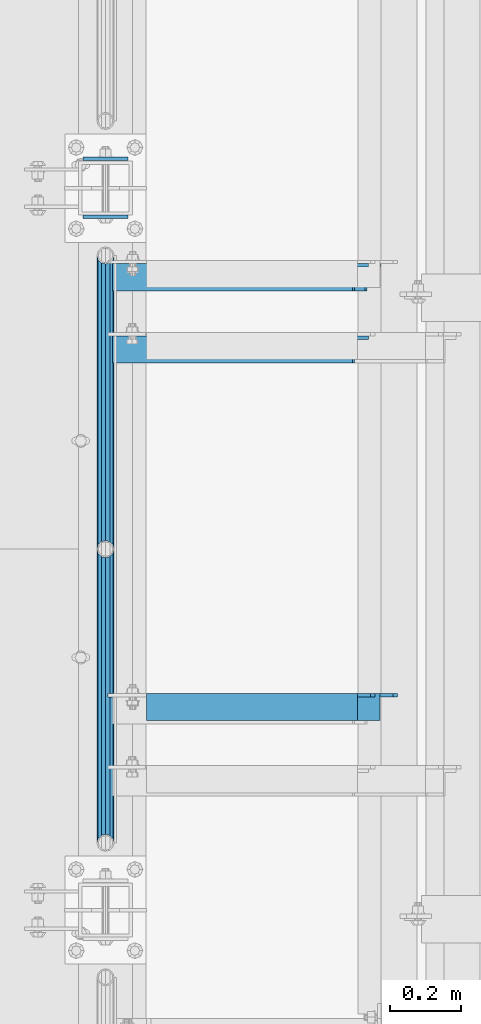
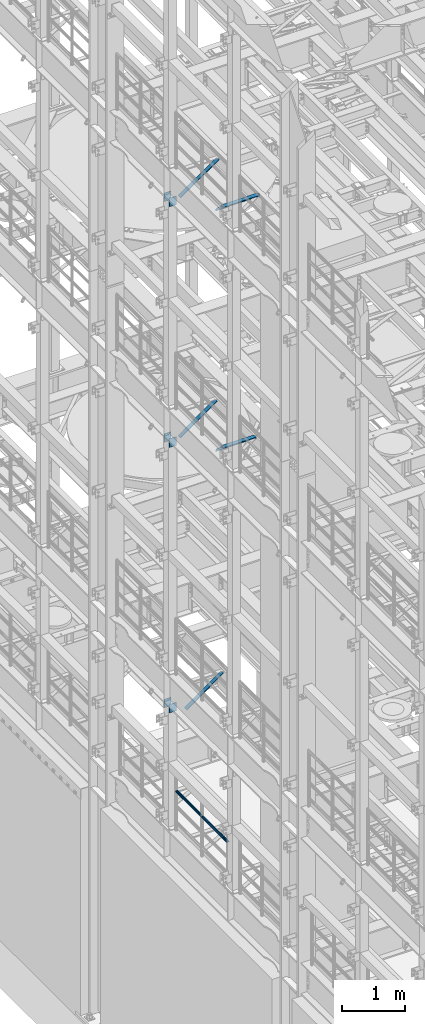
# One storey, part 1254 of 1876: 10 beams, 3 members, 9 elements without a shape of their own.
"""IFC2X3 building model written with IfcOpenShell, lengths in millimetres."""

from ifc_helpers import new_model, si_unit, frame, origin_with_axes, place, context, subcontext, project, spatial, faceted_brep, material, type_object, element, aggregate, save


model = new_model("IFC2X3")

# Units and contexts
model_context = context("Model", 3, precision=1e-05, world=origin_with_axes())
body_context = subcontext(model_context, "Body", "Model", "MODEL_VIEW")
ifc_project = project(units=[si_unit("LENGTHUNIT", "METRE", prefix="MILLI"), si_unit("AREAUNIT", "SQUARE_METRE"), si_unit("VOLUMEUNIT", "CUBIC_METRE"), si_unit("MASSUNIT", "GRAM", prefix="KILO"), si_unit("TIMEUNIT", "SECOND"), si_unit("PLANEANGLEUNIT", "RADIAN"), si_unit("SOLIDANGLEUNIT", "STERADIAN"), si_unit("THERMODYNAMICTEMPERATUREUNIT", "DEGREE_CELSIUS"), si_unit("LUMINOUSINTENSITYUNIT", "LUMEN")], contexts=[model_context])

# Site, building, storey
site_placement = place(None, origin_with_axes())
site = spatial("IfcSite", under=ifc_project, at=site_placement, CompositionType="ELEMENT")
building_placement = place(site_placement, origin_with_axes())
building = spatial("IfcBuilding", under=site, at=building_placement, Name="Undefined", CompositionType="ELEMENT")
storey_placement = place(building_placement, origin_with_axes())
storey = spatial("IfcBuildingStorey", under=building, at=storey_placement, Name="Undefined", CompositionType="ELEMENT", Elevation=0.0)

# Assembly, beams
assembly_1_placement = place(storey_placement, origin_with_axes())
assembly_1 = element("IfcElementAssembly", 1, at=assembly_1_placement, inside=storey, Name="RAIL", AssemblyPlace="NOTDEFINED", PredefinedType="RIGID_FRAME")
ifc_material_1 = material()
beam_type_1 = type_object("IfcBeamType", Name="PIPE1-1/2SCH40", PredefinedType="NOTDEFINED")
beam_1_placement = place(assembly_1_placement, frame((-1.81898940354586e-12, 3745.23, 5902.325), z_axis=(0.0, 0.0, -1.0), x_axis=(0.0, 1.0, 0.0)))
beam_1 = element("IfcBeam", 2, at=beam_1_placement, type_object=beam_type_1, material=ifc_material_1, Name="RAIL", ObjectType="PIPE1-1/2SCH40", context=body_context, shape_type="Brep", body=[
    faceted_brep([(0.0, 24.1299999999992, 0.0), (12.0650000000064, 20.8971929933177, -12.0649999999987), (12.0650000000064, 20.8971929933177, 12.0649999999987), (12.0650000000064, -20.8971929933177, 12.0649999999987), (12.0650000000064, -20.8971929933177, -12.0649999999987), (0.0, -24.1299999999992, 0.0), (20.8971929933249, -12.0650000000005, 20.8971929933177), (20.8971929933249, -12.0650000000005, 15.8661214311796), (15.2545715621445, -17.7076214311801, 10.2235000000001), (12.5151929933249, -20.4470000000001, 0.0), (15.2545715621445, -17.7076214311801, -10.2235000000001), (20.8971929933249, -12.0650000000005, -15.8661214311796), (20.8971929933249, -12.0650000000005, -20.8971929933177), (24.1300000000063, 0.0, -20.4470000000001), (24.1300000000063, 0.0, -24.130000000001), (21.3906214311868, -10.2235000000001, -17.7076214311819), (21.3906214311868, 10.2235000000001, -17.7076214311819), (20.8971929933249, 12.0650000000005, -15.8661214311796), (20.8971929933249, 12.0650000000005, -20.8971929933177), (15.2545715621445, 17.7076214311801, -10.2235000000001), (12.5151929933249, 20.4470000000001, 0.0), (15.2545715621445, 17.7076214311801, 10.2235000000001), (20.8971929933249, 12.0650000000005, 15.8661214311796), (20.8971929933249, 12.0650000000005, 20.8971929933177), (21.3906214311868, 10.2235000000001, 17.7076214311819), (24.1300000000064, 0.0, 20.4470000000001), (24.1300000000064, 0.0, 24.130000000001), (21.3906214311868, -10.2235000000001, 17.7076214311819), (826.77, 24.1300000000001, 0.0), (814.705, 20.8971929933186, -12.0649999999987), (805.872807006681, 12.0649999999996, -20.8971929933177), (826.77, -24.1300000000001, 0.0), (814.705, -20.8971929933186, -12.0649999999987), (814.705, -20.8971929933186, 12.0649999999987), (805.872807006681, -12.0649999999996, 20.8971929933177), (805.872807006681, -12.0649999999996, -20.8971929933177), (802.640000000001, 0.0, -24.130000000001), (805.379378568819, 10.2235000000001, -17.7076214311819), (802.640000000001, 0.0, -20.4470000000001), (805.872807006683, 12.0649999999996, -15.8661214311796), (805.872807006683, -12.0649999999996, -15.8661214311796), (805.379378568819, -10.2235000000001, -17.7076214311819), (811.515428437862, -17.7076214311801, -10.2235000000001), (814.254807006682, -20.4470000000001, 0.0), (811.515428437862, -17.7076214311801, 10.2235000000001), (805.872807006683, -12.0649999999996, 15.8661214311796), (805.379378568819, -10.2235000000001, 17.7076214311819), (802.640000000001, 0.0, 20.4470000000001), (802.640000000001, 0.0, 24.130000000001), (805.872807006681, 12.0649999999996, 20.8971929933177), (814.705, 20.8971929933186, 12.0649999999987), (805.872807006683, 12.0649999999996, 15.8661214311796), (811.515428437862, 17.7076214311801, 10.2235000000001), (814.254807006682, 20.4470000000001, 0.0), (811.515428437862, 17.7076214311801, -10.2235000000001), (805.379378568819, 10.2235000000001, 17.7076214311819)], [[[0, 1, 2]], [[3, 4, 5]], [[6, 7, 8, 9, 10, 11, 12, 4, 3]], [[13, 14, 12, 11, 15]], [[16, 17, 18, 14, 13]], [[2, 1, 18, 17, 19, 20, 21, 22, 23]], [[23, 22, 24, 25, 26]], [[26, 25, 27, 7, 6]], [[1, 0, 28, 29]], [[18, 1, 29, 30]], [[31, 32, 33]], [[6, 3, 33, 34]], [[3, 5, 31, 33]], [[5, 4, 32, 31]], [[4, 12, 35, 32]], [[12, 14, 36, 35]], [[14, 18, 30, 36]], [[37, 38, 36, 30, 39]], [[40, 35, 36, 38, 41]], [[33, 32, 35, 40, 42, 43, 44, 45, 34]], [[34, 45, 46, 47, 48]], [[26, 6, 34, 48]], [[2, 23, 49, 50]], [[23, 26, 48, 49]], [[0, 2, 50, 28]], [[28, 50, 29]], [[49, 51, 52, 53, 54, 39, 30, 29, 50]], [[48, 47, 55, 51, 49]], [[25, 24, 55, 47]], [[55, 24, 22, 21, 52, 51]], [[21, 20, 53, 52]], [[20, 19, 54, 53]], [[19, 17, 16, 37, 39, 54]], [[16, 13, 38, 37]], [[13, 15, 41, 38]], [[41, 15, 11, 10, 42, 40]], [[10, 9, 43, 42]], [[9, 8, 44, 43]], [[8, 7, 27, 46, 45, 44]], [[27, 25, 47, 46]]]),
])
beam_2_placement = place(assembly_1_placement, frame((-1.81898940354586e-12, 4572.0, 5902.325), z_axis=(0.0, 0.0, -1.0), x_axis=(0.0, 1.0, 0.0)))
beam_2 = element("IfcBeam", 3, at=beam_2_placement, type_object=beam_type_1, material=ifc_material_1, Name="RAIL", ObjectType="PIPE1-1/2SCH40", context=body_context, shape_type="Brep", body=[
    faceted_brep([(0.0, 24.1299999999992, 0.0), (12.0650000000064, 20.8971929933177, -12.0649999999987), (12.0650000000064, 20.8971929933177, 12.0649999999987), (12.0650000000064, -20.8971929933177, 12.0649999999987), (12.0650000000064, -20.8971929933177, -12.0649999999987), (0.0, -24.1299999999992, 0.0), (20.8971929933249, -12.0650000000005, 20.8971929933177), (20.8971929933249, -12.0650000000005, 15.8661214311796), (15.2545715621445, -17.7076214311801, 10.2235000000001), (12.5151929933249, -20.4470000000001, 0.0), (15.2545715621445, -17.7076214311801, -10.2235000000001), (20.8971929933249, -12.0650000000005, -15.8661214311796), (20.8971929933249, -12.0650000000005, -20.8971929933177), (24.1300000000063, 0.0, -20.4470000000001), (24.1300000000063, 0.0, -24.130000000001), (21.3906214311868, -10.2235000000001, -17.7076214311819), (21.3906214311868, 10.2235000000001, -17.7076214311819), (20.8971929933249, 12.0650000000005, -15.8661214311796), (20.8971929933249, 12.0650000000005, -20.8971929933177), (15.2545715621445, 17.7076214311801, -10.2235000000001), (12.5151929933249, 20.4470000000001, 0.0), (15.2545715621445, 17.7076214311801, 10.2235000000001), (20.8971929933249, 12.0650000000005, 15.8661214311796), (20.8971929933249, 12.0650000000005, 20.8971929933177), (21.3906214311868, 10.2235000000001, 17.7076214311819), (24.1300000000064, 0.0, 20.4470000000001), (24.1300000000064, 0.0, 24.130000000001), (21.3906214311868, -10.2235000000001, 17.7076214311819), (826.77, 24.1300000000001, 0.0), (814.705, 20.8971929933186, -12.0649999999987), (805.872807006681, 12.0649999999996, -20.8971929933177), (826.77, -24.1300000000001, 0.0), (814.705, -20.8971929933186, -12.0649999999987), (814.705, -20.8971929933186, 12.0649999999987), (805.872807006681, -12.0649999999996, 20.8971929933177), (805.872807006681, -12.0649999999996, -20.8971929933177), (802.640000000001, 0.0, -24.130000000001), (805.379378568819, 10.2235000000001, -17.7076214311819), (802.640000000001, 0.0, -20.4470000000001), (805.872807006683, 12.0649999999996, -15.8661214311796), (805.872807006683, -12.0649999999996, -15.8661214311796), (805.379378568819, -10.2235000000001, -17.7076214311819), (811.515428437862, -17.7076214311801, -10.2235000000001), (814.254807006682, -20.4470000000001, 0.0), (811.515428437862, -17.7076214311801, 10.2235000000001), (805.872807006683, -12.0649999999996, 15.8661214311796), (805.379378568819, -10.2235000000001, 17.7076214311819), (802.640000000001, 0.0, 20.4470000000001), (802.640000000001, 0.0, 24.130000000001), (805.872807006681, 12.0649999999996, 20.8971929933177), (814.705, 20.8971929933186, 12.0649999999987), (805.872807006683, 12.0649999999996, 15.8661214311796), (811.515428437862, 17.7076214311801, 10.2235000000001), (814.254807006682, 20.4470000000001, 0.0), (811.515428437862, 17.7076214311801, -10.2235000000001), (805.379378568819, 10.2235000000001, 17.7076214311819)], [[[0, 1, 2]], [[3, 4, 5]], [[6, 7, 8, 9, 10, 11, 12, 4, 3]], [[13, 14, 12, 11, 15]], [[16, 17, 18, 14, 13]], [[2, 1, 18, 17, 19, 20, 21, 22, 23]], [[23, 22, 24, 25, 26]], [[26, 25, 27, 7, 6]], [[1, 0, 28, 29]], [[18, 1, 29, 30]], [[31, 32, 33]], [[6, 3, 33, 34]], [[3, 5, 31, 33]], [[5, 4, 32, 31]], [[4, 12, 35, 32]], [[12, 14, 36, 35]], [[14, 18, 30, 36]], [[37, 38, 36, 30, 39]], [[40, 35, 36, 38, 41]], [[33, 32, 35, 40, 42, 43, 44, 45, 34]], [[34, 45, 46, 47, 48]], [[26, 6, 34, 48]], [[2, 23, 49, 50]], [[23, 26, 48, 49]], [[0, 2, 50, 28]], [[28, 50, 29]], [[49, 51, 52, 53, 54, 39, 30, 29, 50]], [[48, 47, 55, 51, 49]], [[25, 24, 55, 47]], [[55, 24, 22, 21, 52, 51]], [[21, 20, 53, 52]], [[20, 19, 54, 53]], [[19, 17, 16, 37, 39, 54]], [[16, 13, 38, 37]], [[13, 15, 41, 38]], [[41, 15, 11, 10, 42, 40]], [[10, 9, 43, 42]], [[9, 8, 44, 43]], [[8, 7, 27, 46, 45, 44]], [[27, 25, 47, 46]]]),
])
aggregate(assembly_1, [beam_1, beam_2])

assembly_2_placement = place(storey_placement, origin_with_axes())
assembly_2 = element("IfcElementAssembly", 4, at=assembly_2_placement, inside=storey, Name="BEAM", AssemblyPlace="NOTDEFINED", PredefinedType="RIGID_FRAME")
ifc_material_2 = material(Name="STEEL/A36")
beam_type_2 = type_object("IfcBeamType", PredefinedType="NOTDEFINED")
beam_3_placement = place(assembly_2_placement, frame((-63.6296757345187, 5670.55, 7448.54714244377), z_axis=(5.59490000219896e-05, 0.0, -0.999999998434855), x_axis=(0.999999998434855, 0.0, 5.59490000219868e-05)))
beam_3 = element("IfcBeam", 5, at=beam_3_placement, type_object=beam_type_2, material=ifc_material_2, Name="PLATE", context=body_context, shape_type="Brep", body=[
    faceted_brep([(0.0, 4.76249999999982, -82.5499999999993), (0.0, 4.76249999999982, 82.5499999999993), (127.0, 4.76249999999982, 82.5499999999993), (127.0, 4.76249999999982, -82.5499999999993), (0.0, -4.76249999999982, 82.5499999999993), (127.0, -4.76249999999982, 82.5499999999993), (0.0, -4.76249999999982, -82.5499999999993), (127.0, -4.76249999999982, -82.5499999999993)], [[[0, 1, 2, 3]], [[1, 4, 5, 2]], [[4, 6, 7, 5]], [[6, 0, 3, 7]], [[5, 7, 3, 2]], [[6, 4, 1, 0]]]),
])
beam_4_placement = place(assembly_2_placement, frame((-63.6296757345187, 5507.0375, 7448.54714244377), z_axis=(5.59490000219896e-05, 0.0, -0.999999998434855), x_axis=(0.999999998434855, 0.0, 5.59490000219868e-05)))
beam_4 = element("IfcBeam", 6, at=beam_4_placement, type_object=beam_type_2, material=ifc_material_2, Name="PLATE", context=body_context, shape_type="Brep", body=[
    faceted_brep([(0.0, 4.76249999999982, -82.5499999999993), (0.0, 4.76249999999982, 82.5499999999993), (127.0, 4.76249999999982, 82.5499999999993), (127.0, 4.76249999999982, -82.5499999999993), (0.0, -4.76249999999982, 82.5499999999993), (127.0, -4.76249999999982, 82.5499999999993), (0.0, -4.76249999999982, -82.5499999999993), (127.0, -4.76249999999982, -82.5499999999993)], [[[0, 1, 2, 3]], [[1, 4, 5, 2]], [[4, 6, 7, 5]], [[6, 0, 3, 7]], [[5, 7, 3, 2]], [[6, 4, 1, 0]]]),
])
aggregate(assembly_2, [beam_3, beam_4])

assembly_3_placement = place(storey_placement, origin_with_axes())
assembly_3 = element("IfcElementAssembly", 7, at=assembly_3_placement, inside=storey, Name="BEAM", AssemblyPlace="NOTDEFINED", PredefinedType="RIGID_FRAME")
beam_5_placement = place(assembly_3_placement, frame((-63.6315195800257, 5670.55, 12604.7488224823), z_axis=(2.95459999824743e-05, 0.0, -0.999999999563517), x_axis=(0.999999999563517, 0.0, 2.95459999828704e-05)))
beam_5 = element("IfcBeam", 8, at=beam_5_placement, type_object=beam_type_2, material=ifc_material_2, Name="PLATE", context=body_context, shape_type="Brep", body=[
    faceted_brep([(0.0, 4.76249999999982, -82.5499999999993), (0.0, 4.76249999999982, 82.5499999999993), (127.0, 4.76249999999982, 82.5499999999993), (127.0, 4.76249999999982, -82.5499999999993), (0.0, -4.76249999999982, 82.5499999999993), (127.0, -4.76249999999982, 82.5499999999993), (0.0, -4.76249999999982, -82.5499999999993), (127.0, -4.76249999999982, -82.5499999999993)], [[[0, 1, 2, 3]], [[1, 4, 5, 2]], [[4, 6, 7, 5]], [[6, 0, 3, 7]], [[5, 7, 3, 2]], [[6, 4, 1, 0]]]),
])
beam_6_placement = place(assembly_3_placement, frame((-63.6315195800257, 5507.0375, 12604.7488224823), z_axis=(2.95459999824743e-05, 0.0, -0.999999999563517), x_axis=(0.999999999563517, 0.0, 2.95459999828704e-05)))
beam_6 = element("IfcBeam", 9, at=beam_6_placement, type_object=beam_type_2, material=ifc_material_2, Name="PLATE", context=body_context, shape_type="Brep", body=[
    faceted_brep([(0.0, 4.76249999999982, -82.5499999999993), (0.0, 4.76249999999982, 82.5499999999993), (127.0, 4.76249999999982, 82.5499999999993), (127.0, 4.76249999999982, -82.5499999999993), (0.0, -4.76249999999982, 82.5499999999993), (127.0, -4.76249999999982, 82.5499999999993), (0.0, -4.76249999999982, -82.5499999999993), (127.0, -4.76249999999982, -82.5499999999993)], [[[0, 1, 2, 3]], [[1, 4, 5, 2]], [[4, 6, 7, 5]], [[6, 0, 3, 7]], [[5, 7, 3, 2]], [[6, 4, 1, 0]]]),
])
aggregate(assembly_3, [beam_5, beam_6])

assembly_4_placement = place(storey_placement, origin_with_axes())
assembly_4 = element("IfcElementAssembly", 10, at=assembly_4_placement, inside=storey, Name="BEAM", AssemblyPlace="NOTDEFINED", PredefinedType="RIGID_FRAME")
beam_7_placement = place(assembly_4_placement, frame((-63.5, 5670.55, 17278.35), z_axis=(0.0, 0.0, -1.0), x_axis=(1.0, 0.0, 0.0)))
beam_7 = element("IfcBeam", 11, at=beam_7_placement, type_object=beam_type_2, material=ifc_material_2, Name="PLATE", context=body_context, shape_type="Brep", body=[
    faceted_brep([(0.0, 4.76249999999982, -82.5499999999993), (0.0, 4.76249999999982, 82.5499999999993), (127.0, 4.76249999999982, 82.5499999999993), (127.0, 4.76249999999982, -82.5499999999993), (0.0, -4.76249999999982, 82.5499999999993), (127.0, -4.76249999999982, 82.5499999999993), (0.0, -4.76249999999982, -82.5499999999993), (127.0, -4.76249999999982, -82.5499999999993)], [[[0, 1, 2, 3]], [[1, 4, 5, 2]], [[4, 6, 7, 5]], [[6, 0, 3, 7]], [[5, 7, 3, 2]], [[6, 4, 1, 0]]]),
])
beam_8_placement = place(assembly_4_placement, frame((-63.5, 5507.0375, 17278.35), z_axis=(0.0, 0.0, -1.0), x_axis=(1.0, 0.0, 0.0)))
beam_8 = element("IfcBeam", 12, at=beam_8_placement, type_object=beam_type_2, material=ifc_material_2, Name="PLATE", context=body_context, shape_type="Brep", body=[
    faceted_brep([(0.0, 4.76249999999982, -82.5499999999993), (0.0, 4.76249999999982, 82.5499999999993), (127.0, 4.76249999999982, 82.5499999999993), (127.0, 4.76249999999982, -82.5499999999993), (0.0, -4.76249999999982, 82.5499999999993), (127.0, -4.76249999999982, 82.5499999999993), (0.0, -4.76249999999982, -82.5499999999993), (127.0, -4.76249999999982, -82.5499999999993)], [[[0, 1, 2, 3]], [[1, 4, 5, 2]], [[4, 6, 7, 5]], [[6, 0, 3, 7]], [[5, 7, 3, 2]], [[6, 4, 1, 0]]]),
])
aggregate(assembly_4, [beam_7, beam_8])

# Assembly, member
assembly_5_placement = place(storey_placement, origin_with_axes())
assembly_5 = element("IfcElementAssembly", 13, at=assembly_5_placement, inside=storey, AssemblyPlace="NOTDEFINED", PredefinedType="RIGID_FRAME")
member_type = type_object("IfcMemberType", Name="L3X3X3/8", PredefinedType="NOTDEFINED")
member_1_placement = place(assembly_5_placement, frame((22.1939709589552, 5133.975, 7601.73169287095), z_axis=(0.0, -1.0, 0.0), x_axis=(0.812817140855119, 0.0, 0.582518922896166)))
member_1 = element("IfcMember", 14, at=member_1_placement, type_object=member_type, material=ifc_material_2, ObjectType="L3X3X3/8", context=body_context, shape_type="Brep", body=[
    faceted_brep([(24.4135476554111, 38.1000000000058, -38.0999999999999), (24.4135476554111, 38.1000000000058, 38.0999999999999), (855.72322987264, 38.1000000000749, 38.0999999999999), (855.72322987264, 38.1000000000749, -38.0999999999999), (24.4135476554093, 28.5750000000053, 38.0999999999999), (855.723229872639, 28.5750000000744, 38.0999999999999), (24.4135476554093, 28.5750000000053, -28.5749999999998), (855.723229872639, 28.5750000000744, -28.5749999999998), (24.4135476553975, -38.1000000000031, -28.5749999999998), (855.723229872628, -38.0999999999331, -28.5749999999998), (24.4135476553975, -38.1000000000031, -38.0999999999999), (855.723229872628, -38.0999999999331, -38.0999999999999)], [[[0, 1, 2, 3]], [[1, 4, 5, 2]], [[4, 6, 7, 5]], [[6, 8, 9, 7]], [[8, 10, 11, 9]], [[10, 0, 3, 11]], [[5, 7, 9, 11, 3, 2]], [[10, 8, 6, 4, 1, 0]]]),
])
aggregate(assembly_5, [member_1])

assembly_6_placement = place(storey_placement, origin_with_axes())
assembly_6 = element("IfcElementAssembly", 15, at=assembly_6_placement, inside=storey, Name="BRACE", AssemblyPlace="NOTDEFINED", PredefinedType="RIGID_FRAME")
member_2_placement = place(assembly_6_placement, frame((22.1939716660531, 5337.175, 12757.9316674292), z_axis=(0.0, -1.0, 0.0), x_axis=(0.812817140855119, 0.0, 0.582518922896166)))
member_2 = element("IfcMember", 16, at=member_2_placement, type_object=member_type, material=ifc_material_2, Name="BRACE", ObjectType="L3X3X3/8", context=body_context, shape_type="Brep", body=[
    faceted_brep([(855.723229872639, 28.5750000000744, 38.0999999999999), (855.723229872639, 28.5750000000744, -28.5749999999998), (855.723229872628, -38.0999999999331, -28.5749999999998), (855.723229872628, -38.0999999999331, -38.0999999999999), (855.72322987264, 38.1000000000749, -38.0999999999999), (855.72322987264, 38.1000000000749, 38.0999999999999), (24.4135476554093, 28.5750000000053, 38.0999999999999), (24.4135476554093, 28.5750000000053, -28.5749999999998), (24.4135476553975, -38.1000000000031, -28.5749999999998), (24.4135476553975, -38.1000000000031, -38.0999999999999), (24.4135476554111, 38.1000000000058, -38.0999999999999), (24.4135476554111, 38.1000000000058, 38.0999999999999)], [[[0, 1, 2, 3, 4, 5]], [[6, 7, 1, 0]], [[7, 8, 2, 1]], [[8, 9, 3, 2]], [[9, 10, 4, 3]], [[10, 11, 5, 4]], [[11, 6, 0, 5]], [[9, 8, 7, 6, 11, 10]]]),
])
aggregate(assembly_6, [member_2])

assembly_7_placement = place(storey_placement, origin_with_axes())
assembly_7 = element("IfcElementAssembly", 17, at=assembly_7_placement, inside=storey, AssemblyPlace="NOTDEFINED", PredefinedType="RIGID_FRAME")
member_3_placement = place(assembly_7_placement, frame((21.6869001657126, 5337.175, 17424.2669187563), z_axis=(0.0, -1.0, 0.0), x_axis=(0.822192192147785, 0.0, 0.569209978102299)))
member_3 = element("IfcMember", 18, at=member_3_placement, type_object=member_type, material=ifc_material_2, ObjectType="L3X3X3/8", context=body_context, shape_type="Brep", body=[
    faceted_brep([(24.1351720308776, 38.0999999999403, -38.1000000000004), (24.1351720308776, 38.0999999999403, 38.0999999999999), (887.866654075793, 38.0999999989017, 38.0999999999999), (887.866654075793, 38.0999999989017, -38.1000000000004), (24.135172030894, 28.5749999999462, 38.0999999999999), (887.866654075808, 28.5749999989075, 38.0999999999999), (24.135172030894, 28.5749999999462, -28.5749999999998), (887.866654075808, 28.5749999989075, -28.5749999999998), (24.1351720310122, -38.0999999999985, -28.5749999999998), (887.86665407593, -38.1000000010354, -28.5749999999998), (24.1351720310122, -38.0999999999985, -38.1000000000004), (887.86665407593, -38.1000000010354, -38.1000000000004)], [[[0, 1, 2, 3]], [[1, 4, 5, 2]], [[4, 6, 7, 5]], [[6, 8, 9, 7]], [[8, 10, 11, 9]], [[10, 0, 3, 11]], [[5, 7, 9, 11, 3, 2]], [[10, 8, 6, 4, 1, 0]]]),
])
aggregate(assembly_7, [member_3])

# Assembly, beam
assembly_8_placement = place(storey_placement, origin_with_axes())
assembly_8 = element("IfcElementAssembly", 19, at=assembly_8_placement, inside=storey, Name="ANGLE", AssemblyPlace="NOTDEFINED", PredefinedType="RIGID_FRAME")
beam_type_3 = type_object("IfcBeamType", Name="L3X3X3/8", PredefinedType="NOTDEFINED")
beam_9_placement = place(assembly_8_placement, frame((-1.44313229599957e-09, 4127.5, 17945.1), z_axis=(0.0, -1.0, 0.0), x_axis=(1.0, 0.0, 0.0)))
beam_9 = element("IfcBeam", 20, at=beam_9_placement, type_object=beam_type_3, material=ifc_material_2, Name="ANGLE", ObjectType="L3X3X3/8", context=body_context, shape_type="Brep", body=[
    faceted_brep([(773.112500001443, 28.5750000000007, -28.5749999999998), (773.112500001443, 28.5750000000007, 38.0999999999999), (115.886999817316, 28.5750000000007, 38.0999999999999), (115.88699895052, 28.5750000000007, -28.5749999999998), (773.112500001443, 38.0999999999985, 38.0999999999999), (115.886999817316, 38.0999999999985, 38.0999999999999), (115.886998950515, 12.699999237062, -28.5749999999998), (115.88699882669, 12.699999237062, -38.0999999999999), (38.8937432114558, 12.699999237062, -38.0999999999999), (38.8937433352807, 12.699999237062, -28.5749999999998), (115.886998826692, 38.0999999999985, -38.0999999999999), (773.112500001443, 38.0999999999985, -38.1000000000004), (773.112500001443, 28.5750000000007, -38.1000000000004), (809.625001718057, 28.5750000000007, -28.5749999999998), (809.625001718057, 28.5750000000007, -38.1000000000004), (822.325001527322, 15.8750001907356, -28.5749999999998), (822.325001527322, 15.8750001907356, -38.1000000000004), (822.325001527322, -38.1000030517571, -28.5749999999998), (822.325001527322, -38.0999999999985, -38.1000000000004), (7.1437499954859, -38.0999999999985, -28.5749999999998), (7.1437499954859, -38.0999999999985, -38.0999999999999), (7.14374321145577, -19.050000762938, -38.0999999999999), (7.14374333528067, -19.050000762938, -28.5749999999998)], [[[0, 1, 2, 3]], [[1, 4, 5, 2]], [[6, 7, 8, 9]], [[2, 5, 10, 7, 6, 3]], [[4, 11, 10, 5]], [[1, 0, 12, 11, 4]], [[13, 14, 12, 0]], [[15, 16, 14, 13]], [[17, 18, 16, 15]], [[18, 17, 19, 20]], [[8, 7, 10, 11, 12, 14, 16, 18, 20, 21]], [[9, 8, 21, 22]], [[17, 15, 13, 0, 3, 6, 9, 22, 19]], [[21, 20, 19, 22]]]),
])
aggregate(assembly_8, [beam_9])

assembly_9_placement = place(storey_placement, origin_with_axes())
assembly_9 = element("IfcElementAssembly", 21, at=assembly_9_placement, inside=storey, Name="ANGLE", AssemblyPlace="NOTDEFINED", PredefinedType="RIGID_FRAME")
beam_10_placement = place(assembly_9_placement, frame((-8.61482369428009e-09, 4127.5, 13271.5), z_axis=(0.0, -1.0, 0.0), x_axis=(1.0, 0.0, 0.0)))
beam_10 = element("IfcBeam", 22, at=beam_10_placement, type_object=beam_type_3, material=ifc_material_2, Name="ANGLE", ObjectType="L3X3X3/8", context=body_context, shape_type="Brep", body=[
    faceted_brep([(115.886999817316, 28.5750000000007, 38.0999999999999), (115.886999817316, 38.0999999999985, 38.0999999999999), (115.886998826692, 38.0999999999985, -38.0999999999999), (115.88699882669, 12.699999237062, -38.0999999999999), (115.886998950515, 12.699999237062, -28.5749999999998), (115.88699895052, 28.5750000000007, -28.5749999999998), (38.8937432114558, 12.699999237062, -38.0999999999999), (38.8937433352807, 12.699999237062, -28.5749999999998), (7.14374321145577, -19.050000762938, -38.0999999999999), (7.14374333528067, -19.050000762938, -28.5749999999998), (7.1437499954859, -38.0999999999985, -38.0999999999999), (7.1437499954859, -38.0999999999985, -28.5749999999998), (758.82500204062, 14.2880005577626, -28.5749999999998), (746.125002396449, 26.9880005321429, -28.5749999999998), (709.613000600291, 26.9880010068428, -28.5749999999998), (709.61300062358, 28.5749999999998, -28.5749999999998), (758.824999999999, -38.1000000000004, -28.5749999999998), (758.825001875526, 1.58799979482319, -28.5749999999998), (709.613002423808, 28.5749999999998, 38.1000000000004), (709.613002423808, 38.1000000000004, 38.1000000000004), (709.613000366395, 38.1000000000004, -38.1000000000004), (709.613000343115, 26.9880010068428, -38.1000000000004), (746.125002139273, 26.9880005321429, -38.1000000000004), (758.825001783445, 14.2880005577626, -38.1000000000004), (758.825001618351, 1.58799979482319, -38.1000000000004), (758.824999999999, -38.1000000000004, -38.1000000000004)], [[[0, 1, 2, 3, 4, 5]], [[4, 3, 6, 7]], [[7, 6, 8, 9]], [[8, 10, 11, 9]], [[12, 13, 14, 15, 5, 4, 7, 9, 11, 16, 17]], [[0, 5, 15, 18]], [[1, 0, 18, 19]], [[2, 1, 19, 20]], [[18, 15, 14, 21, 20, 19]], [[13, 22, 21, 14]], [[12, 23, 22, 13]], [[17, 24, 23, 12]], [[10, 8, 6, 3, 2, 20, 21, 22, 23, 24, 25]], [[11, 10, 25, 16]], [[24, 17, 16, 25]]]),
])
aggregate(assembly_9, [beam_10])

save(model, "model.ifc")
